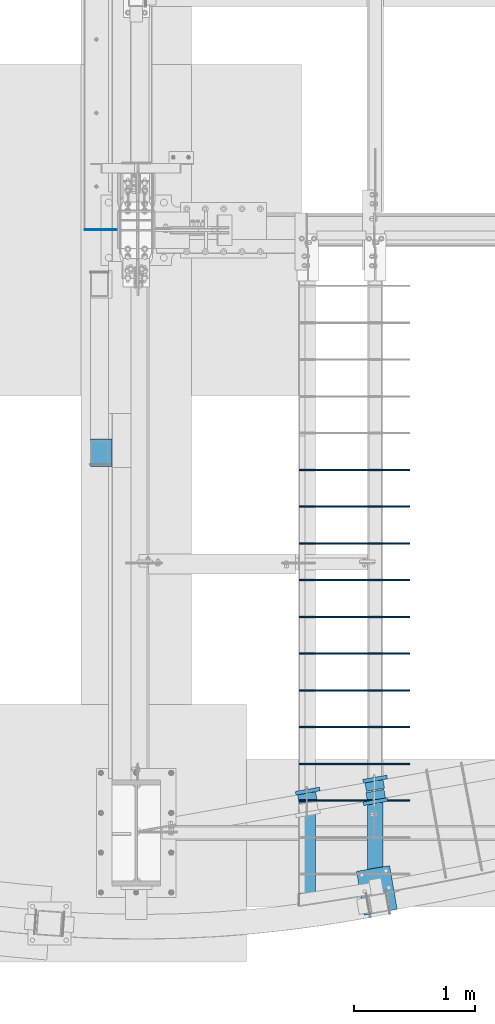
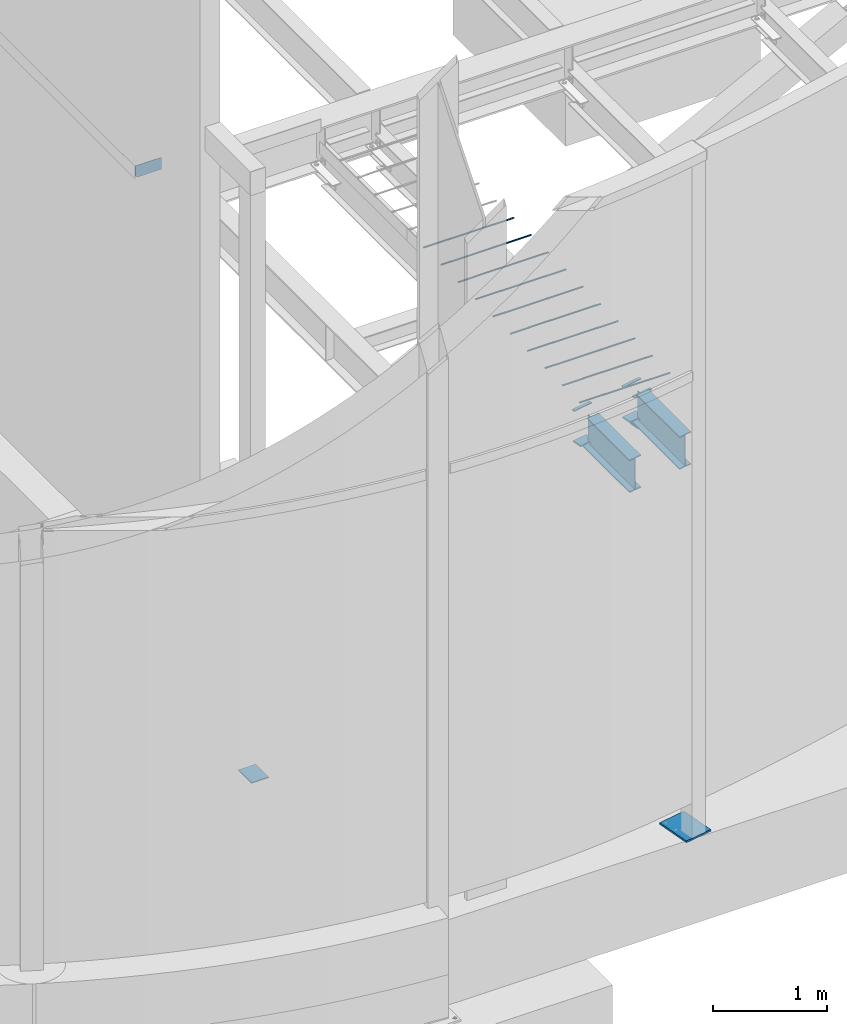
# One storey, part 804 of 1179: 21 beams, 17 elements without a shape of their own.
"""IFC2X3 building model written with IfcOpenShell, lengths in millimetres."""

from ifc_helpers import new_model, si_unit, frame, origin_with_axes, place, context, subcontext, project, spatial, faceted_brep, material, type_object, element, aggregate, save


model = new_model("IFC2X3")

# Units and contexts
model_context = context("Model", 3, precision=1e-05, world=origin_with_axes())
body_context = subcontext(model_context, "Body", "Model", "MODEL_VIEW")
ifc_project = project(units=[si_unit("LENGTHUNIT", "METRE", prefix="MILLI"), si_unit("AREAUNIT", "SQUARE_METRE"), si_unit("VOLUMEUNIT", "CUBIC_METRE"), si_unit("MASSUNIT", "GRAM", prefix="KILO"), si_unit("TIMEUNIT", "SECOND"), si_unit("PLANEANGLEUNIT", "RADIAN"), si_unit("SOLIDANGLEUNIT", "STERADIAN"), si_unit("THERMODYNAMICTEMPERATUREUNIT", "DEGREE_CELSIUS"), si_unit("LUMINOUSINTENSITYUNIT", "LUMEN")], contexts=[model_context])

# Site, building, storey
site_placement = place(None, origin_with_axes())
site = spatial("IfcSite", under=ifc_project, at=site_placement, CompositionType="ELEMENT")
building_placement = place(site_placement, origin_with_axes())
building = spatial("IfcBuilding", under=site, at=building_placement, Name="Undefined", CompositionType="ELEMENT")
storey_placement = place(building_placement, origin_with_axes())
storey = spatial("IfcBuildingStorey", under=building, at=storey_placement, Name="Undefined", CompositionType="ELEMENT", Elevation=0.0)

# Assembly, beam
assembly_1_placement = place(storey_placement, origin_with_axes())
assembly_1 = element("IfcElementAssembly", 1, at=assembly_1_placement, inside=storey, Name="BEAM", AssemblyPlace="NOTDEFINED", PredefinedType="RIGID_FRAME")
ifc_material_1 = material(Name="STEEL/A36")
beam_type_1 = type_object("IfcBeamType", PredefinedType="NOTDEFINED")
beam_1_placement = place(assembly_1_placement, frame((1850.19942198764, 800.247024962561, 3831.8280002594), z_axis=(-0.984527722010802, -0.175228892001923, 0.0), x_axis=(0.175228892001915, -0.984527722010803, 0.0)))
beam_1 = element("IfcBeam", 2, at=beam_1_placement, type_object=beam_type_1, material=ifc_material_1, Name="PLATE", context=body_context, shape_type="Brep", body=[
    faceted_brep([(0.0, 4.76250000000073, -101.6), (0.0, 4.76250000000073, 101.6), (31.75, 4.76249999999982, 101.6), (31.75, 4.76249999999982, -101.6), (0.0, -4.76250000000073, 101.6), (31.75, -4.76249999999982, 101.6), (0.0, -4.76250000000073, -101.6), (31.75, -4.76249999999982, -101.6)], [[[0, 1, 2, 3]], [[1, 4, 5, 2]], [[4, 6, 7, 5]], [[6, 0, 3, 7]], [[5, 7, 3, 2]], [[6, 4, 1, 0]]]),
])

assembly_2_placement = place(storey_placement, origin_with_axes())
assembly_2 = element("IfcElementAssembly", 3, at=assembly_2_placement, inside=storey, Name="BEAM", AssemblyPlace="NOTDEFINED", PredefinedType="RIGID_FRAME")
beam_2_placement = place(assembly_2_placement, frame((2408.99942198764, 899.70375194094, 3831.8280002594), z_axis=(-0.984527722010802, -0.175228892001923, 0.0), x_axis=(0.175228892001915, -0.984527722010803, 0.0)))
beam_2 = element("IfcBeam", 4, at=beam_2_placement, type_object=beam_type_1, material=ifc_material_1, Name="PLATE", context=body_context, shape_type="Brep", body=[
    faceted_brep([(0.0, 4.76250000000073, -101.6), (0.0, 4.76250000000073, 101.6), (31.75, 4.76249999999982, 101.6), (31.75, 4.76249999999982, -101.6), (0.0, -4.76250000000073, 101.6), (31.75, -4.76249999999982, 101.6), (0.0, -4.76250000000073, -101.6), (31.75, -4.76249999999982, -101.6)], [[[0, 1, 2, 3]], [[1, 4, 5, 2]], [[4, 6, 7, 5]], [[6, 0, 3, 7]], [[5, 7, 3, 2]], [[6, 4, 1, 0]]]),
])

assembly_3_placement = place(storey_placement, origin_with_axes())
assembly_3 = element("IfcElementAssembly", 5, at=assembly_3_placement, inside=storey, Name="BEAM", AssemblyPlace="NOTDEFINED", PredefinedType="RIGID_FRAME")
beam_3_placement = place(assembly_3_placement, frame((2417.00057801337, 681.834857542228, 3831.8280002594), z_axis=(0.984527722010802, 0.175228892001923, 0.0), x_axis=(-0.175228892001923, 0.984527722010802, 0.0)))
beam_3 = element("IfcBeam", 6, at=beam_3_placement, type_object=beam_type_1, material=ifc_material_1, Name="PLATE", context=body_context, shape_type="Brep", body=[
    faceted_brep([(0.0, 4.76250000000073, -101.6), (0.0, 4.76250000000073, 101.6), (31.75, 4.76249999999982, 101.6), (31.75, 4.76249999999982, -101.6), (0.0, -4.76250000000073, 101.6), (31.75, -4.76249999999982, 101.6), (0.0, -4.76250000000073, -101.6), (31.75, -4.76249999999982, -101.6)], [[[0, 1, 2, 3]], [[1, 4, 5, 2]], [[4, 6, 7, 5]], [[6, 0, 3, 7]], [[5, 7, 3, 2]], [[6, 4, 1, 0]]]),
])

assembly_4_placement = place(storey_placement, origin_with_axes())
assembly_4 = element("IfcElementAssembly", 7, at=assembly_4_placement, inside=storey, Name="BEAM", AssemblyPlace="NOTDEFINED", PredefinedType="RIGID_FRAME")
beam_type_2 = type_object("IfcBeamType", PredefinedType="NOTDEFINED")
beam_4_placement = place(assembly_4_placement, frame((6.3500024130005, 5438.775, 4171.95), z_axis=(0.0, 0.0, 1.0), x_axis=(0.999999999556486, 2.97829999855756e-05, 2.29999993865945e-08)))
beam_4 = element("IfcBeam", 8, at=beam_4_placement, type_object=beam_type_2, material=ifc_material_1, Name="PLATE", context=body_context, shape_type="Brep", body=[
    faceted_brep([(0.0, 3.17499999999995, -44.4499999999998), (19.0499999999993, 3.17499999999995, -63.5), (19.0499999999993, -3.17499999999995, -63.5), (0.0, -3.17499999999995, -44.4499999999998), (0.0, 3.17499999999927, 63.5), (263.524999994857, 3.17499999999927, 63.5), (263.524996884716, 3.17500000007112, -63.4999999999445), (0.0, -3.17499999999927, 63.5), (263.524999994857, -3.17499999999927, 63.5), (263.524996884716, -3.17499999992833, -63.4999999999427)], [[[0, 1, 2, 3]], [[4, 5, 6, 1, 0]], [[4, 7, 8, 5]], [[9, 8, 7, 3, 2]], [[6, 9, 2, 1]], [[8, 9, 6, 5]], [[7, 4, 0, 3]]]),
])
aggregate(assembly_4, [beam_4])

# Beam
beam_type_3 = type_object("IfcBeamType", PredefinedType="NOTDEFINED")
beam_5_placement = place(assembly_1_placement, frame((1838.74115130958, 796.595202880921, 3487.7375), z_axis=(-0.984527722010802, -0.175228892001923, 0.0), x_axis=(0.175228892001915, -0.984527722010803, 0.0)))
beam_5 = element("IfcBeam", 9, at=beam_5_placement, type_object=beam_type_3, material=ifc_material_1, Name="PLATE", context=body_context, shape_type="Brep", body=[
    faceted_brep([(3.78008735424373e-12, 7.9375, -76.200000000003), (-3.72324393538292e-12, 7.9375, 76.2000000000037), (101.600000000008, 7.9375, 76.1999999999971), (101.600000000016, 7.9375, -76.2000000000096), (-3.72324393538292e-12, -7.9375, 76.2000000000037), (101.600000000008, -7.9375, 76.1999999999971), (3.78008735424373e-12, -7.9375, -76.200000000003), (101.600000000016, -7.9375, -76.2000000000096)], [[[0, 1, 2, 3]], [[1, 4, 5, 2]], [[4, 6, 7, 5]], [[6, 0, 3, 7]], [[5, 7, 3, 2]], [[6, 4, 1, 0]]]),
])

aggregate(assembly_1, [beam_1, beam_5])

beam_6_placement = place(assembly_2_placement, frame((2397.5411513096, 896.051929859277, 3487.7375), z_axis=(-0.984527722010802, -0.175228892001923, 0.0), x_axis=(0.175228892001915, -0.984527722010803, 0.0)))
beam_6 = element("IfcBeam", 10, at=beam_6_placement, type_object=beam_type_3, material=ifc_material_1, Name="PLATE", context=body_context, shape_type="Brep", body=[
    faceted_brep([(3.78008735424373e-12, 7.9375, -76.200000000003), (-3.72324393538292e-12, 7.9375, 76.2000000000037), (101.600000000008, 7.9375, 76.1999999999971), (101.600000000016, 7.9375, -76.2000000000096), (-3.72324393538292e-12, -7.9375, 76.2000000000037), (101.600000000008, -7.9375, 76.1999999999971), (3.78008735424373e-12, -7.9375, -76.200000000003), (101.600000000016, -7.9375, -76.2000000000096)], [[[0, 1, 2, 3]], [[1, 4, 5, 2]], [[4, 6, 7, 5]], [[6, 0, 3, 7]], [[5, 7, 3, 2]], [[6, 4, 1, 0]]]),
])

aggregate(assembly_2, [beam_2, beam_6])

beam_7_placement = place(assembly_3_placement, frame((2428.4588486904, 685.486679623778, 3487.7375), z_axis=(0.984527722010802, 0.175228892001923, 0.0), x_axis=(-0.175228892001923, 0.984527722010802, 0.0)))
beam_7 = element("IfcBeam", 11, at=beam_7_placement, type_object=beam_type_3, material=ifc_material_1, Name="PLATE", context=body_context, shape_type="Brep", body=[
    faceted_brep([(3.78008735424373e-12, 7.9375, -76.200000000003), (-3.72324393538292e-12, 7.9375, 76.2000000000037), (101.600000000008, 7.9375, 76.1999999999971), (101.600000000016, 7.9375, -76.2000000000096), (-3.72324393538292e-12, -7.9375, 76.2000000000037), (101.600000000008, -7.9375, 76.1999999999971), (3.78008735424373e-12, -7.9375, -76.200000000003), (101.600000000016, -7.9375, -76.2000000000096)], [[[0, 1, 2, 3]], [[1, 4, 5, 2]], [[4, 6, 7, 5]], [[6, 0, 3, 7]], [[5, 7, 3, 2]], [[6, 4, 1, 0]]]),
])

# Assembly, beam
assembly_5_placement = place(storey_placement, origin_with_axes())
assembly_5 = element("IfcElementAssembly", 12, at=assembly_5_placement, inside=storey, Name="#4 DOWEL", AssemblyPlace="NOTDEFINED", PredefinedType="NOTDEFINED")
ifc_material_2 = material(Name="REBAR/A615-40")
beam_type_4 = type_object("IfcBeamType", Name="#4 DOWEL", PredefinedType="NOTDEFINED")
beam_8_placement = place(assembly_5_placement, frame((1784.35000076294, 3448.94259468122, 3943.35000610352), z_axis=(0.0, 1.0, 0.0), x_axis=(1.0, 0.0, 0.0)))
beam_8 = element("IfcBeam", 13, at=beam_8_placement, type_object=beam_type_4, material=ifc_material_2, Name="#4 DOWEL", ObjectType="#4 DOWEL", context=body_context, shape_type="Brep", body=[
    faceted_brep([(0.0, -6.34999999999854, 0.0), (0.0, -4.49012806053361, -4.49012806053452), (914.399999999994, -4.49012806053452, -4.49012806042992), (914.399999999994, -6.34999999999991, 1.0550138540566e-10), (0.0, 0.0, -6.34999999999991), (914.399999999994, 0.0, -6.34999999989668), (0.0, 4.49012806053361, -4.49012806053452), (914.399999999994, 4.49012806053452, -4.49012806042992), (0.0, 6.34999999999854, 0.0), (914.399999999994, 6.34999999999991, 1.0550138540566e-10), (0.0, 4.49012806053361, 4.49012806053452), (914.399999999995, 4.49012806053452, 4.49012806064184), (0.0, 0.0, 6.34999999999991), (914.399999999995, 0.0, 6.35000000010768), (0.0, -4.49012806053361, 4.49012806053452), (914.399999999995, -4.49012806053452, 4.49012806064184)], [[[0, 1, 2, 3]], [[1, 4, 5, 2]], [[4, 6, 7, 5]], [[6, 8, 9, 7]], [[8, 10, 11, 9]], [[10, 12, 13, 11]], [[12, 14, 15, 13]], [[14, 0, 3, 15]], [[5, 7, 9, 11, 13, 15, 3, 2]], [[14, 12, 10, 8, 6, 4, 1, 0]]]),
])
aggregate(assembly_5, [beam_8])

assembly_6_placement = place(storey_placement, origin_with_axes())
assembly_6 = element("IfcElementAssembly", 14, at=assembly_6_placement, inside=storey, Name="#4 DOWEL", AssemblyPlace="NOTDEFINED", PredefinedType="NOTDEFINED")
beam_9_placement = place(assembly_6_placement, frame((1784.35000076294, 3144.14259468122, 3943.35000610352), z_axis=(0.0, 1.0, 0.0), x_axis=(1.0, 0.0, 0.0)))
beam_9 = element("IfcBeam", 15, at=beam_9_placement, type_object=beam_type_4, material=ifc_material_2, Name="#4 DOWEL", ObjectType="#4 DOWEL", context=body_context, shape_type="Brep", body=[
    faceted_brep([(0.0, -6.34999999999854, 0.0), (0.0, -4.49012806053361, -4.49012806053452), (914.399999999994, -4.49012806053452, -4.49012806042992), (914.399999999994, -6.34999999999991, 1.0550138540566e-10), (0.0, 0.0, -6.34999999999991), (914.399999999994, 0.0, -6.34999999989668), (0.0, 4.49012806053361, -4.49012806053452), (914.399999999994, 4.49012806053452, -4.49012806042992), (0.0, 6.34999999999854, 0.0), (914.399999999994, 6.34999999999991, 1.0550138540566e-10), (0.0, 4.49012806053361, 4.49012806053452), (914.399999999995, 4.49012806053452, 4.49012806064184), (0.0, 0.0, 6.34999999999991), (914.399999999995, 0.0, 6.35000000010768), (0.0, -4.49012806053361, 4.49012806053452), (914.399999999995, -4.49012806053452, 4.49012806064184)], [[[0, 1, 2, 3]], [[1, 4, 5, 2]], [[4, 6, 7, 5]], [[6, 8, 9, 7]], [[8, 10, 11, 9]], [[10, 12, 13, 11]], [[12, 14, 15, 13]], [[14, 0, 3, 15]], [[5, 7, 9, 11, 13, 15, 3, 2]], [[14, 12, 10, 8, 6, 4, 1, 0]]]),
])
aggregate(assembly_6, [beam_9])

assembly_7_placement = place(storey_placement, origin_with_axes())
assembly_7 = element("IfcElementAssembly", 16, at=assembly_7_placement, inside=storey, Name="#4 DOWEL", AssemblyPlace="NOTDEFINED", PredefinedType="NOTDEFINED")
beam_10_placement = place(assembly_7_placement, frame((1784.35000076294, 2839.34259468122, 3943.35000610352), z_axis=(0.0, 1.0, 0.0), x_axis=(1.0, 0.0, 0.0)))
beam_10 = element("IfcBeam", 17, at=beam_10_placement, type_object=beam_type_4, material=ifc_material_2, Name="#4 DOWEL", ObjectType="#4 DOWEL", context=body_context, shape_type="Brep", body=[
    faceted_brep([(0.0, -6.34999999999854, 0.0), (0.0, -4.49012806053361, -4.49012806053452), (914.399999999994, -4.49012806053452, -4.49012806042992), (914.399999999994, -6.34999999999991, 1.0550138540566e-10), (0.0, 0.0, -6.34999999999991), (914.399999999994, 0.0, -6.34999999989668), (0.0, 4.49012806053361, -4.49012806053452), (914.399999999994, 4.49012806053452, -4.49012806042992), (0.0, 6.34999999999854, 0.0), (914.399999999994, 6.34999999999991, 1.0550138540566e-10), (0.0, 4.49012806053361, 4.49012806053452), (914.399999999995, 4.49012806053452, 4.49012806064184), (0.0, 0.0, 6.34999999999991), (914.399999999995, 0.0, 6.35000000010768), (0.0, -4.49012806053361, 4.49012806053452), (914.399999999995, -4.49012806053452, 4.49012806064184)], [[[0, 1, 2, 3]], [[1, 4, 5, 2]], [[4, 6, 7, 5]], [[6, 8, 9, 7]], [[8, 10, 11, 9]], [[10, 12, 13, 11]], [[12, 14, 15, 13]], [[14, 0, 3, 15]], [[5, 7, 9, 11, 13, 15, 3, 2]], [[14, 12, 10, 8, 6, 4, 1, 0]]]),
])
aggregate(assembly_7, [beam_10])

assembly_8_placement = place(storey_placement, origin_with_axes())
assembly_8 = element("IfcElementAssembly", 18, at=assembly_8_placement, inside=storey, Name="#4 DOWEL", AssemblyPlace="NOTDEFINED", PredefinedType="NOTDEFINED")
beam_11_placement = place(assembly_8_placement, frame((1784.35000076294, 2534.54259468122, 3943.35000610352), z_axis=(0.0, 1.0, 0.0), x_axis=(1.0, 0.0, 0.0)))
beam_11 = element("IfcBeam", 19, at=beam_11_placement, type_object=beam_type_4, material=ifc_material_2, Name="#4 DOWEL", ObjectType="#4 DOWEL", context=body_context, shape_type="Brep", body=[
    faceted_brep([(0.0, -6.34999999999854, 0.0), (0.0, -4.49012806053361, -4.49012806053452), (914.399999999994, -4.49012806053452, -4.49012806042992), (914.399999999994, -6.34999999999991, 1.0550138540566e-10), (0.0, 0.0, -6.34999999999991), (914.399999999994, 0.0, -6.34999999989668), (0.0, 4.49012806053361, -4.49012806053452), (914.399999999994, 4.49012806053452, -4.49012806042992), (0.0, 6.34999999999854, 0.0), (914.399999999994, 6.34999999999991, 1.0550138540566e-10), (0.0, 4.49012806053361, 4.49012806053452), (914.399999999995, 4.49012806053452, 4.49012806064184), (0.0, 0.0, 6.34999999999991), (914.399999999995, 0.0, 6.35000000010768), (0.0, -4.49012806053361, 4.49012806053452), (914.399999999995, -4.49012806053452, 4.49012806064184)], [[[0, 1, 2, 3]], [[1, 4, 5, 2]], [[4, 6, 7, 5]], [[6, 8, 9, 7]], [[8, 10, 11, 9]], [[10, 12, 13, 11]], [[12, 14, 15, 13]], [[14, 0, 3, 15]], [[5, 7, 9, 11, 13, 15, 3, 2]], [[14, 12, 10, 8, 6, 4, 1, 0]]]),
])
aggregate(assembly_8, [beam_11])

assembly_9_placement = place(storey_placement, origin_with_axes())
assembly_9 = element("IfcElementAssembly", 20, at=assembly_9_placement, inside=storey, Name="#4 DOWEL", AssemblyPlace="NOTDEFINED", PredefinedType="NOTDEFINED")
beam_12_placement = place(assembly_9_placement, frame((1784.35000076294, 2229.74259468122, 3943.35000610352), z_axis=(0.0, 1.0, 0.0), x_axis=(1.0, 0.0, 0.0)))
beam_12 = element("IfcBeam", 21, at=beam_12_placement, type_object=beam_type_4, material=ifc_material_2, Name="#4 DOWEL", ObjectType="#4 DOWEL", context=body_context, shape_type="Brep", body=[
    faceted_brep([(0.0, -6.34999999999854, 0.0), (0.0, -4.49012806053361, -4.49012806053452), (914.399999999994, -4.49012806053452, -4.49012806042992), (914.399999999994, -6.34999999999991, 1.0550138540566e-10), (0.0, 0.0, -6.34999999999991), (914.399999999994, 0.0, -6.34999999989668), (0.0, 4.49012806053361, -4.49012806053452), (914.399999999994, 4.49012806053452, -4.49012806042992), (0.0, 6.34999999999854, 0.0), (914.399999999994, 6.34999999999991, 1.0550138540566e-10), (0.0, 4.49012806053361, 4.49012806053452), (914.399999999995, 4.49012806053452, 4.49012806064184), (0.0, 0.0, 6.34999999999991), (914.399999999995, 0.0, 6.35000000010768), (0.0, -4.49012806053361, 4.49012806053452), (914.399999999995, -4.49012806053452, 4.49012806064184)], [[[0, 1, 2, 3]], [[1, 4, 5, 2]], [[4, 6, 7, 5]], [[6, 8, 9, 7]], [[8, 10, 11, 9]], [[10, 12, 13, 11]], [[12, 14, 15, 13]], [[14, 0, 3, 15]], [[5, 7, 9, 11, 13, 15, 3, 2]], [[14, 12, 10, 8, 6, 4, 1, 0]]]),
])
aggregate(assembly_9, [beam_12])

assembly_10_placement = place(storey_placement, origin_with_axes())
assembly_10 = element("IfcElementAssembly", 22, at=assembly_10_placement, inside=storey, Name="#4 DOWEL", AssemblyPlace="NOTDEFINED", PredefinedType="NOTDEFINED")
beam_13_placement = place(assembly_10_placement, frame((1784.35000076294, 1924.94259468122, 3943.35000610352), z_axis=(0.0, 1.0, 0.0), x_axis=(1.0, 0.0, 0.0)))
beam_13 = element("IfcBeam", 23, at=beam_13_placement, type_object=beam_type_4, material=ifc_material_2, Name="#4 DOWEL", ObjectType="#4 DOWEL", context=body_context, shape_type="Brep", body=[
    faceted_brep([(0.0, -6.34999999999854, 0.0), (0.0, -4.49012806053361, -4.49012806053452), (914.399999999994, -4.49012806053452, -4.49012806042992), (914.399999999994, -6.34999999999991, 1.0550138540566e-10), (0.0, 0.0, -6.34999999999991), (914.399999999994, 0.0, -6.34999999989668), (0.0, 4.49012806053361, -4.49012806053452), (914.399999999994, 4.49012806053452, -4.49012806042992), (0.0, 6.34999999999854, 0.0), (914.399999999994, 6.34999999999991, 1.0550138540566e-10), (0.0, 4.49012806053361, 4.49012806053452), (914.399999999995, 4.49012806053452, 4.49012806064184), (0.0, 0.0, 6.34999999999991), (914.399999999995, 0.0, 6.35000000010768), (0.0, -4.49012806053361, 4.49012806053452), (914.399999999995, -4.49012806053452, 4.49012806064184)], [[[0, 1, 2, 3]], [[1, 4, 5, 2]], [[4, 6, 7, 5]], [[6, 8, 9, 7]], [[8, 10, 11, 9]], [[10, 12, 13, 11]], [[12, 14, 15, 13]], [[14, 0, 3, 15]], [[5, 7, 9, 11, 13, 15, 3, 2]], [[14, 12, 10, 8, 6, 4, 1, 0]]]),
])
aggregate(assembly_10, [beam_13])

assembly_11_placement = place(storey_placement, origin_with_axes())
assembly_11 = element("IfcElementAssembly", 24, at=assembly_11_placement, inside=storey, Name="#4 DOWEL", AssemblyPlace="NOTDEFINED", PredefinedType="NOTDEFINED")
beam_14_placement = place(assembly_11_placement, frame((1784.35000076294, 1620.14259468122, 3943.35000610352), z_axis=(0.0, 1.0, 0.0), x_axis=(1.0, 0.0, 0.0)))
beam_14 = element("IfcBeam", 25, at=beam_14_placement, type_object=beam_type_4, material=ifc_material_2, Name="#4 DOWEL", ObjectType="#4 DOWEL", context=body_context, shape_type="Brep", body=[
    faceted_brep([(0.0, -6.34999999999854, 0.0), (0.0, -4.49012806053361, -4.49012806053452), (914.399999999994, -4.49012806053452, -4.49012806042992), (914.399999999994, -6.34999999999991, 1.0550138540566e-10), (0.0, 0.0, -6.34999999999991), (914.399999999994, 0.0, -6.34999999989668), (0.0, 4.49012806053361, -4.49012806053452), (914.399999999994, 4.49012806053452, -4.49012806042992), (0.0, 6.34999999999854, 0.0), (914.399999999994, 6.34999999999991, 1.0550138540566e-10), (0.0, 4.49012806053361, 4.49012806053452), (914.399999999995, 4.49012806053452, 4.49012806064184), (0.0, 0.0, 6.34999999999991), (914.399999999995, 0.0, 6.35000000010768), (0.0, -4.49012806053361, 4.49012806053452), (914.399999999995, -4.49012806053452, 4.49012806064184)], [[[0, 1, 2, 3]], [[1, 4, 5, 2]], [[4, 6, 7, 5]], [[6, 8, 9, 7]], [[8, 10, 11, 9]], [[10, 12, 13, 11]], [[12, 14, 15, 13]], [[14, 0, 3, 15]], [[5, 7, 9, 11, 13, 15, 3, 2]], [[14, 12, 10, 8, 6, 4, 1, 0]]]),
])
aggregate(assembly_11, [beam_14])

assembly_12_placement = place(storey_placement, origin_with_axes())
assembly_12 = element("IfcElementAssembly", 26, at=assembly_12_placement, inside=storey, Name="#4 DOWEL", AssemblyPlace="NOTDEFINED", PredefinedType="NOTDEFINED")
beam_15_placement = place(assembly_12_placement, frame((1784.35000076294, 1315.34259468122, 3943.35000610352), z_axis=(0.0, 1.0, 0.0), x_axis=(1.0, 0.0, 0.0)))
beam_15 = element("IfcBeam", 27, at=beam_15_placement, type_object=beam_type_4, material=ifc_material_2, Name="#4 DOWEL", ObjectType="#4 DOWEL", context=body_context, shape_type="Brep", body=[
    faceted_brep([(0.0, -6.34999999999854, 0.0), (0.0, -4.49012806053361, -4.49012806053452), (914.399999999994, -4.49012806053452, -4.49012806042992), (914.399999999994, -6.34999999999991, 1.0550138540566e-10), (0.0, 0.0, -6.34999999999991), (914.399999999994, 0.0, -6.34999999989668), (0.0, 4.49012806053361, -4.49012806053452), (914.399999999994, 4.49012806053452, -4.49012806042992), (0.0, 6.34999999999854, 0.0), (914.399999999994, 6.34999999999991, 1.0550138540566e-10), (0.0, 4.49012806053361, 4.49012806053452), (914.399999999995, 4.49012806053452, 4.49012806064184), (0.0, 0.0, 6.34999999999991), (914.399999999995, 0.0, 6.35000000010768), (0.0, -4.49012806053361, 4.49012806053452), (914.399999999995, -4.49012806053452, 4.49012806064184)], [[[0, 1, 2, 3]], [[1, 4, 5, 2]], [[4, 6, 7, 5]], [[6, 8, 9, 7]], [[8, 10, 11, 9]], [[10, 12, 13, 11]], [[12, 14, 15, 13]], [[14, 0, 3, 15]], [[5, 7, 9, 11, 13, 15, 3, 2]], [[14, 12, 10, 8, 6, 4, 1, 0]]]),
])
aggregate(assembly_12, [beam_15])

assembly_13_placement = place(storey_placement, origin_with_axes())
assembly_13 = element("IfcElementAssembly", 28, at=assembly_13_placement, inside=storey, Name="#4 DOWEL", AssemblyPlace="NOTDEFINED", PredefinedType="NOTDEFINED")
beam_16_placement = place(assembly_13_placement, frame((1784.35000076294, 1010.54259468122, 3943.35000610352), z_axis=(0.0, 1.0, 0.0), x_axis=(1.0, 0.0, 0.0)))
beam_16 = element("IfcBeam", 29, at=beam_16_placement, type_object=beam_type_4, material=ifc_material_2, Name="#4 DOWEL", ObjectType="#4 DOWEL", context=body_context, shape_type="Brep", body=[
    faceted_brep([(0.0, -6.34999999999854, 0.0), (0.0, -4.49012806053361, -4.49012806053452), (914.399999999994, -4.49012806053452, -4.49012806042992), (914.399999999994, -6.34999999999991, 1.0550138540566e-10), (0.0, 0.0, -6.34999999999991), (914.399999999994, 0.0, -6.34999999989668), (0.0, 4.49012806053361, -4.49012806053452), (914.399999999994, 4.49012806053452, -4.49012806042992), (0.0, 6.34999999999854, 0.0), (914.399999999994, 6.34999999999991, 1.0550138540566e-10), (0.0, 4.49012806053361, 4.49012806053452), (914.399999999995, 4.49012806053452, 4.49012806064184), (0.0, 0.0, 6.34999999999991), (914.399999999995, 0.0, 6.35000000010768), (0.0, -4.49012806053361, 4.49012806053452), (914.399999999995, -4.49012806053452, 4.49012806064184)], [[[0, 1, 2, 3]], [[1, 4, 5, 2]], [[4, 6, 7, 5]], [[6, 8, 9, 7]], [[8, 10, 11, 9]], [[10, 12, 13, 11]], [[12, 14, 15, 13]], [[14, 0, 3, 15]], [[5, 7, 9, 11, 13, 15, 3, 2]], [[14, 12, 10, 8, 6, 4, 1, 0]]]),
])
aggregate(assembly_13, [beam_16])

assembly_14_placement = place(storey_placement, origin_with_axes())
assembly_14 = element("IfcElementAssembly", 30, at=assembly_14_placement, inside=storey, Name="#4 DOWEL", AssemblyPlace="NOTDEFINED", PredefinedType="NOTDEFINED")
beam_17_placement = place(assembly_14_placement, frame((1784.35000076294, 705.742594681217, 3943.35000610352), z_axis=(0.0, 1.0, 0.0), x_axis=(1.0, 0.0, 0.0)))
beam_17 = element("IfcBeam", 31, at=beam_17_placement, type_object=beam_type_4, material=ifc_material_2, Name="#4 DOWEL", ObjectType="#4 DOWEL", context=body_context, shape_type="Brep", body=[
    faceted_brep([(0.0, -6.34999999999854, 0.0), (0.0, -4.49012806053361, -4.49012806053452), (914.399999999994, -4.49012806053452, -4.49012806042992), (914.399999999994, -6.34999999999991, 1.0550138540566e-10), (0.0, 0.0, -6.34999999999991), (914.399999999994, 0.0, -6.34999999989668), (0.0, 4.49012806053361, -4.49012806053452), (914.399999999994, 4.49012806053452, -4.49012806042992), (0.0, 6.34999999999854, 0.0), (914.399999999994, 6.34999999999991, 1.0550138540566e-10), (0.0, 4.49012806053361, 4.49012806053452), (914.399999999995, 4.49012806053452, 4.49012806064184), (0.0, 0.0, 6.34999999999991), (914.399999999995, 0.0, 6.35000000010768), (0.0, -4.49012806053361, 4.49012806053452), (914.399999999995, -4.49012806053452, 4.49012806064184)], [[[0, 1, 2, 3]], [[1, 4, 5, 2]], [[4, 6, 7, 5]], [[6, 8, 9, 7]], [[8, 10, 11, 9]], [[10, 12, 13, 11]], [[12, 14, 15, 13]], [[14, 0, 3, 15]], [[5, 7, 9, 11, 13, 15, 3, 2]], [[14, 12, 10, 8, 6, 4, 1, 0]]]),
])
aggregate(assembly_14, [beam_17])

assembly_15_placement = place(storey_placement, origin_with_axes())
assembly_15 = element("IfcElementAssembly", 32, at=assembly_15_placement, inside=storey, Name="BEAM", AssemblyPlace="NOTDEFINED", PredefinedType="RIGID_FRAME")
ifc_material_3 = material(Name="STEEL/A992")
beam_type_5 = type_object("IfcBeamType", Name="W14X26", PredefinedType="NOTDEFINED")
beam_18_placement = place(assembly_15_placement, frame((1854.2, -283.590314832945, 3671.8875), z_axis=(0.0, 0.0, 1.0), x_axis=(0.0, 1.0, 0.0)))
beam_18 = element("IfcBeam", 33, at=beam_18_placement, type_object=beam_type_5, material=ifc_material_3, Name="BEAM", ObjectType="W14X26", context=body_context, shape_type="Brep", body=[
    faceted_brep([(971.692759280043, -63.5, -176.2125), (949.088957694039, 63.5, -176.2125), (942.572894381678, 63.5, -165.1), (953.30970013503, 3.17499999999995, -165.1), (953.076910443713, 3.17499999999995, -164.703000259397), (954.207100523013, -3.17499999999995, -164.703000259397), (954.43989021433, -3.17499999999995, -165.1), (965.176695967682, -63.5, -165.1), (936.719634563285, 3.17499999999995, -164.703000259397), (937.849824642584, -3.17499999999995, -164.703000259397), (920.133979109323, 3.17499999999995, -158.045004848505), (921.264169188623, -3.17499999999995, -158.045004848505), (915.985046607933, 3.17499999999995, -154.857742002598), (917.115236687232, -3.17499999999995, -154.857742002598), (914.144471902459, 3.17499999999995, -150.003873155926), (915.274661981758, -3.17499999999995, -150.003873155926), (915.1568410293, 3.17499999999995, -144.919552564304), (916.2870311086, -3.17499999999995, -144.919552564304), (918.722615975401, 3.17499999999995, -141.109120144247), (919.852806054701, -3.17499999999995, -141.109120144247), (923.786761463566, 3.17499999999995, -139.699999999997), (924.916951542865, -3.17499999999995, -139.699999999997), (956.60086644367, 3.17499999999995, -139.699999999997), (957.73105652297, -3.17499999999995, -139.699999999997), (957.73105652297, -3.17499999999995, 139.700000000001), (956.60086644367, 3.17499999999995, 139.700000000001), (851.526529606579, 3.17499999999995, 139.700000000001), (852.656719685879, -3.17499999999995, 139.700000000001), (846.462384118413, 3.17499999999995, 141.10912014425), (847.592574197713, -3.17499999999995, 141.10912014425), (842.896609172312, 3.17499999999995, 144.919552564307), (844.026799251612, -3.17499999999995, 144.919552564307), (841.88424004547, 3.17499999999995, 150.003873155929), (843.01443012477, -3.17499999999995, 150.003873155929), (843.724814750944, 3.17499999999995, 154.857742002602), (844.855004830244, -3.17499999999995, 154.857742002602), (847.873747252336, 3.17499999999995, 158.045004848508), (849.003937331636, -3.17499999999995, 158.045004848508), (864.459402706298, 3.17499999999995, 164.7030002594), (865.589592785598, -3.17499999999995, 164.7030002594), (887.03278787657, 3.17499999999995, 164.7030002594), (888.16297795587, -3.17499999999995, 164.7030002594), (898.666980574029, -63.5, 165.1), (887.930174820678, -3.17499999999995, 165.1), (886.799984741377, 3.17499999999995, 165.1), (876.063178988026, 63.5, 165.1), (869.546739365388, 63.5, 176.2125), (892.150540951392, -63.5, 176.2125), (145.368204298104, -63.5, 176.2125), (145.368204298104, -63.5, 165.1), (136.160387365199, -3.17499999999995, 165.1), (136.160387365199, -3.17499999999995, -165.1), (145.368204298104, -63.5, -165.1), (145.368204298104, -63.5, -176.2125), (125.983326544619, 63.5, -176.2125), (125.983326544619, 63.5, -165.1), (135.191143477524, 3.17499999999995, -165.1), (135.191143477524, 3.17499999999995, 165.1), (125.983326544619, 63.5, 165.1), (125.983326544619, 63.5, 176.2125)], [[[0, 1, 2, 3, 4, 5, 6, 7]], [[8, 9, 5, 4]], [[9, 8, 10, 11]], [[11, 10, 12, 13]], [[13, 12, 14, 15]], [[15, 14, 16, 17]], [[17, 16, 18, 19]], [[19, 18, 20, 21]], [[21, 20, 22, 23]], [[24, 23, 22, 25]], [[26, 27, 24, 25]], [[27, 26, 28, 29]], [[29, 28, 30, 31]], [[31, 30, 32, 33]], [[33, 32, 34, 35]], [[35, 34, 36, 37]], [[37, 36, 38, 39]], [[39, 38, 40, 41]], [[42, 43, 41, 40, 44, 45, 46, 47]], [[42, 47, 48, 49]], [[43, 42, 49, 50]], [[6, 5, 9, 11, 13, 15, 17, 19, 21, 23, 24, 27, 29, 31, 33, 35, 37, 39, 41, 43, 50, 51]], [[7, 6, 51, 52]], [[0, 7, 52, 53]], [[1, 0, 53, 54]], [[2, 1, 54, 55]], [[3, 2, 55, 56]], [[44, 40, 38, 36, 34, 32, 30, 28, 26, 25, 22, 20, 18, 16, 14, 12, 10, 8, 4, 3, 56, 57]], [[45, 44, 57, 58]], [[46, 45, 58, 59]], [[47, 46, 59, 48]], [[58, 57, 56, 55, 54, 53, 52, 51, 50, 49, 48, 59]]]),
])
aggregate(assembly_15, [beam_18])

# Beam
beam_19_placement = place(assembly_3_placement, frame((2413.0, -149.371726623296, 3671.8875), z_axis=(0.0, 0.0, 1.0), x_axis=(0.0, 1.0, 0.0)))
beam_19 = element("IfcBeam", 34, at=beam_19_placement, type_object=beam_type_5, material=ifc_material_3, Name="BEAM", ObjectType="W14X26", context=body_context, shape_type="Brep", body=[
    faceted_brep([(936.930898048964, -63.5, -176.2125), (914.32709646296, 63.5, -176.2125), (907.811033150599, 63.5, -165.1), (918.547838903951, 3.17500000000018, -165.1), (918.315049212635, 3.17500000000018, -164.703000259399), (919.445239291935, -3.17500000000018, -164.703000259399), (919.678028983251, -3.17500000000018, -165.1), (930.414834736603, -63.5, -165.1), (901.957773332166, 3.17500000000018, -164.703000259399), (903.087963411466, -3.17500000000018, -164.703000259399), (885.372117878204, 3.17500000000018, -158.045004848507), (886.502307957504, -3.17500000000018, -158.045004848507), (881.223185376814, 3.17500000000018, -154.857742002601), (882.353375456113, -3.17500000000018, -154.857742002601), (879.38261067134, 3.17500000000018, -150.003873155929), (880.512800750639, -3.17500000000018, -150.003873155929), (880.394979798181, 3.17500000000018, -144.919552564306), (881.525169877481, -3.17500000000018, -144.919552564306), (883.960754744283, 3.17500000000018, -141.10912014425), (885.090944823582, -3.17500000000018, -141.10912014425), (889.024900232447, 3.17500000000018, -139.7), (890.155090311747, -3.17500000000018, -139.7), (921.839005212768, 3.17500000000018, -139.7), (922.969195292068, -3.17500000000018, -139.7), (922.969195292068, -3.17500000000018, 139.7), (921.839005212768, 3.17500000000018, 139.7), (816.764668375461, 3.17500000000018, 139.7), (817.894858454761, -3.17500000000018, 139.7), (811.700522887295, 3.17500000000018, 141.10912014425), (812.830712966595, -3.17500000000018, 141.10912014425), (808.134747941194, 3.17500000000018, 144.919552564306), (809.264938020494, -3.17500000000018, 144.919552564306), (807.122378814352, 3.17500000000018, 150.003873155928), (808.252568893652, -3.17500000000018, 150.003873155928), (808.962953519826, 3.17500000000018, 154.857742002601), (810.093143599126, -3.17500000000018, 154.857742002601), (813.111886021218, 3.17500000000018, 158.045004848507), (814.242076100518, -3.17500000000018, 158.045004848507), (829.69754147518, 3.17500000000018, 164.703000259399), (830.82773155448, -3.17500000000018, 164.703000259399), (852.270926645445, 3.17500000000018, 164.703000259399), (853.401116724745, -3.17500000000018, 164.703000259399), (863.905119342904, -63.5, 165.1), (853.168313589552, -3.17500000000018, 165.1), (852.038123510252, 3.17500000000018, 165.1), (841.3013177569, 63.5, 165.1), (834.784878134263, 63.5, 176.2125), (857.388679720267, -63.5, 176.2125), (100.383574960678, -63.5, 176.2125), (100.383574960678, -63.5, 165.1), (90.513306120369, -3.17500000000018, 165.1), (90.513306120369, -3.17500000000018, -165.1), (100.383574960678, -63.5, -165.1), (100.383574960678, -63.5, -176.2125), (79.6040616126592, 63.5, -176.2125), (79.6040616126592, 63.5, -165.1), (89.474330452968, 3.17500000000018, -165.1), (89.474330452968, 3.17500000000018, 165.1), (79.6040616126592, 63.5, 165.1), (79.6040616126592, 63.5, 176.2125)], [[[0, 1, 2, 3, 4, 5, 6, 7]], [[8, 9, 5, 4]], [[9, 8, 10, 11]], [[11, 10, 12, 13]], [[13, 12, 14, 15]], [[15, 14, 16, 17]], [[17, 16, 18, 19]], [[19, 18, 20, 21]], [[21, 20, 22, 23]], [[24, 23, 22, 25]], [[26, 27, 24, 25]], [[27, 26, 28, 29]], [[29, 28, 30, 31]], [[31, 30, 32, 33]], [[33, 32, 34, 35]], [[35, 34, 36, 37]], [[37, 36, 38, 39]], [[39, 38, 40, 41]], [[42, 43, 41, 40, 44, 45, 46, 47]], [[42, 47, 48, 49]], [[43, 42, 49, 50]], [[6, 5, 9, 11, 13, 15, 17, 19, 21, 23, 24, 27, 29, 31, 33, 35, 37, 39, 41, 43, 50, 51]], [[7, 6, 51, 52]], [[0, 7, 52, 53]], [[1, 0, 53, 54]], [[2, 1, 54, 55]], [[3, 2, 55, 56]], [[44, 40, 38, 36, 34, 32, 30, 28, 26, 25, 22, 20, 18, 16, 14, 12, 10, 8, 4, 3, 56, 57]], [[45, 44, 57, 58]], [[46, 45, 58, 59]], [[47, 46, 59, 48]], [[58, 57, 56, 55, 54, 53, 52, 51, 50, 49, 48, 59]]]),
])

aggregate(assembly_3, [beam_3, beam_7, beam_19])

# Assembly, beam
assembly_16_placement = place(storey_placement, origin_with_axes())
assembly_16 = element("IfcElementAssembly", 35, at=assembly_16_placement, inside=storey, Name="COLUMN", AssemblyPlace="NOTDEFINED", PredefinedType="RIGID_FRAME")
beam_type_6 = type_object("IfcBeamType", PredefinedType="NOTDEFINED")
beam_20_placement = place(assembly_16_placement, frame((139.7, 3476.625, -1214.4375), z_axis=(-1.0, 0.0, 0.0), x_axis=(0.0, 1.0, 0.0)))
beam_20 = element("IfcBeam", 36, at=beam_20_placement, type_object=beam_type_6, material=ifc_material_1, Name="PLATE", context=body_context, shape_type="Brep", body=[
    faceted_brep([(0.0, 4.76250000000005, -88.9), (0.0, 4.76250000000005, 88.9), (228.6, 4.76250000000005, 88.9), (228.6, 4.76250000000005, -88.9), (0.0, -4.76250000000005, 88.9), (228.6, -4.76250000000005, 88.9), (0.0, -4.76250000000005, -88.9), (228.6, -4.76250000000005, -88.9)], [[[0, 1, 2, 3]], [[1, 4, 5, 2]], [[4, 6, 7, 5]], [[6, 0, 3, 7]], [[5, 7, 3, 2]], [[6, 4, 1, 0]]]),
])
aggregate(assembly_16, [beam_20])

assembly_17_placement = place(storey_placement, origin_with_axes())
assembly_17 = element("IfcElementAssembly", 37, at=assembly_17_placement, inside=storey, Name="COLUMN", AssemblyPlace="NOTDEFINED", PredefinedType="RIGID_FRAME")
ifc_material_4 = material(Name="STEEL/A572-GR.50")
beam_type_7 = type_object("IfcBeamType", PredefinedType="NOTDEFINED")
beam_21_placement = place(assembly_17_placement, frame((2288.78304537191, -61.7364366099175, -384.175), z_axis=(-0.169391131050126, 0.985548905291645, 0.0), x_axis=(0.985548905291645, 0.169391131050126, 0.0)))
beam_21 = element("IfcBeam", 38, at=beam_21_placement, type_object=beam_type_7, material=ifc_material_4, context=body_context, shape_type="Brep", body=[
    faceted_brep([(-4.00177668780088e-11, 9.52499999999998, -184.149999999993), (4.04725142288953e-11, 9.52499999999998, 184.149999999993), (279.399999999923, 9.52499999999998, 184.149999999996), (279.399999999843, 9.52499999999998, -184.14999999999), (4.04725142288953e-11, -9.52499999999998, 184.149999999993), (279.399999999923, -9.52499999999998, 184.149999999996), (-4.00177668780088e-11, -9.52499999999998, -184.149999999993), (279.399999999843, -9.52499999999998, -184.14999999999)], [[[0, 1, 2, 3]], [[1, 4, 5, 2]], [[4, 6, 7, 5]], [[6, 0, 3, 7]], [[5, 7, 3, 2]], [[6, 4, 1, 0]]]),
])
aggregate(assembly_17, [beam_21])

save(model, "model.ifc")
